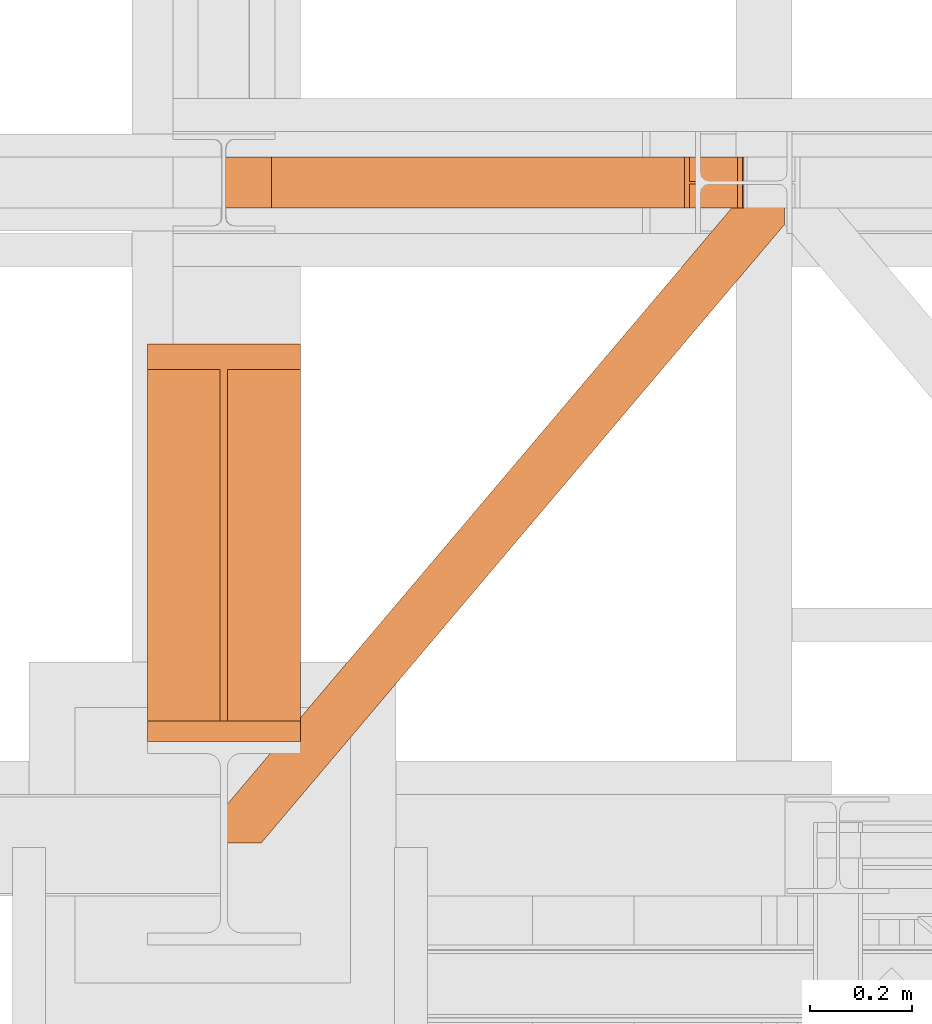
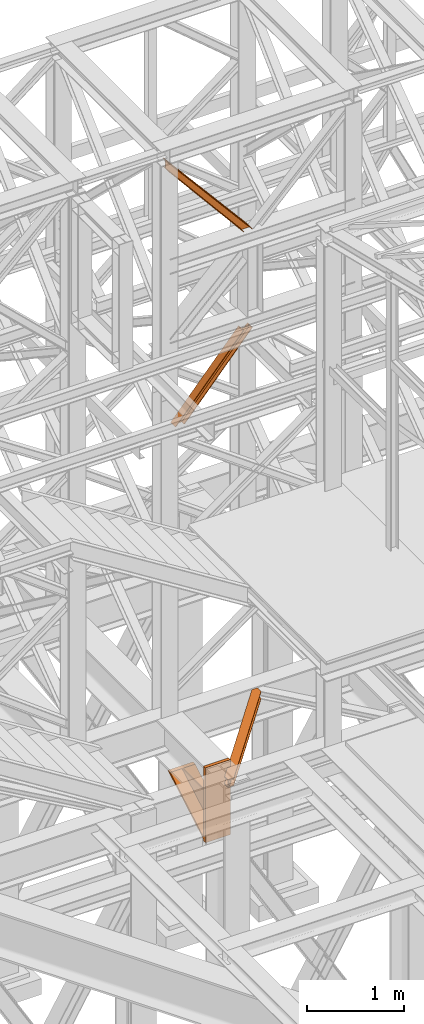
# One storey, part 106 of 208: 4 proxies.
"""IFC2X3 building model written with IfcOpenShell, lengths in millimetres."""

import ifcopenshell
import ifcopenshell.guid

model = None  # the IFC model being written
_history = None  # IfcOwnerHistory: only IFC2X3 demands one
_inside = {}  # id of a spatial element -> (the spatial element, [elements in it])
_under = {}  # id of a project, library or spatial element -> (it, [spatial elements below it])
_declared = {}  # id of a project -> (the project, [libraries it declares])
_typed = {}  # id of a type object -> (the type object, [elements of that type])
_made_of = {}  # id of a material, layer set ... -> (it, [elements and type objects made of it])


def new_model(schema):
    """Start an empty IFC model of exactly this schema.

    Asked for "IFC4X3", IfcOpenShell would pick the latest addendum, in which some entities
    have other attributes; the version numbers below select the first issue.
    IFC2X3 requires an IfcOwnerHistory on every rooted entity: one is made here for all.
    """
    global model, _history
    if schema == "IFC4X3":
        model = ifcopenshell.file(schema_version=(4, 3, 0, 0))
    else:
        model = ifcopenshell.file(schema=schema)
    _inside.clear()
    _under.clear()
    _declared.clear()
    _typed.clear()
    _made_of.clear()
    _history = None
    if model.schema == "IFC2X3":
        org = make("IfcOrganization", Name="unknown")
        user = make(
            "IfcPersonAndOrganization",
            ThePerson=make("IfcPerson", FamilyName="unknown"),
            TheOrganization=org,
        )
        app = make(
            "IfcApplication",
            ApplicationDeveloper=org,
            Version="unknown",
            ApplicationFullName="unknown",
            ApplicationIdentifier="unknown",
        )
        _history = make(
            "IfcOwnerHistory",
            OwningUser=user,
            OwningApplication=app,
            ChangeAction="ADDED",
            CreationDate=0,
        )
    return model


def make(cls, **values):
    """One entity of the class cls with the attributes given. An attribute that is None is left unset."""
    return model.create_entity(
        cls, **{name: value for name, value in values.items() if value is not None}
    )


def entity(cls, *values):
    """Any entity or typed value of the class cls, its attributes in the order of the schema. None: left unset."""
    e = model.create_entity(cls)
    for i, value in enumerate(values):
        if value is not None:
            e[i] = value
    return e


def rooted(cls, **values):
    """An entity with a GlobalId (a new one), such as an element, a storey or a relation."""
    return make(cls, GlobalId=ifcopenshell.guid.new(), OwnerHistory=_history, **values)


def si_unit(unit_type, name, prefix=None):
    """IfcSIUnit, for example si_unit("LENGTHUNIT", "METRE", prefix="MILLI")."""
    return make("IfcSIUnit", UnitType=unit_type, Prefix=prefix, Name=name)


def converted_unit(unit_type, name, factor, base, dimensions=None, offset=None):
    """IfcConversionBasedUnit, such as the inch: factor (a typed value) times the base unit."""
    return make(
        "IfcConversionBasedUnit"
        if offset is None
        else "IfcConversionBasedUnitWithOffset",
        ConversionOffset=offset,
        Dimensions=None
        if dimensions is None
        else entity("IfcDimensionalExponents", *dimensions),
        UnitType=unit_type,
        Name=name,
        ConversionFactor=make(
            "IfcMeasureWithUnit", ValueComponent=factor, UnitComponent=base
        ),
    )


def assignment(units):
    """IfcUnitAssignment: the units of a project."""
    return None if units is None else make("IfcUnitAssignment", Units=units)


def point(xyz):
    """IfcCartesianPoint."""
    return None if xyz is None else make("IfcCartesianPoint", Coordinates=xyz)


def direction(xyz):
    """IfcDirection."""
    return None if xyz is None else make("IfcDirection", DirectionRatios=xyz)


def frame(location, z_axis=None, x_axis=None):
    """IfcAxis2Placement3D, a coordinate frame: its origin and axes. An axis left out is left unset."""
    return make(
        "IfcAxis2Placement3D",
        Location=point(location),
        Axis=direction(z_axis),
        RefDirection=direction(x_axis),
    )


def origin():
    """The frame at (0, 0, 0) with its axes left unset."""
    return frame((0.0, 0.0, 0.0))


def origin_with_axes():
    """The frame at (0, 0, 0) with the z axis (0, 0, 1) and the x axis (1, 0, 0) written out."""
    return frame((0.0, 0.0, 0.0), z_axis=(0.0, 0.0, 1.0), x_axis=(1.0, 0.0, 0.0))


def place(relative_to, where):
    """IfcLocalPlacement: puts the frame where relative to a parent placement (None: the world)."""
    return make(
        "IfcLocalPlacement", PlacementRelTo=relative_to, RelativePlacement=where
    )


def context(
    kind, dimensions, precision=None, world=None, true_north=None, identifier=None
):
    """IfcGeometricRepresentationContext, for example the 3D "Model" context."""
    return make(
        "IfcGeometricRepresentationContext",
        ContextIdentifier=identifier,
        ContextType=kind,
        CoordinateSpaceDimension=dimensions,
        Precision=precision,
        WorldCoordinateSystem=world,
        TrueNorth=true_north,
    )


def subcontext(parent, identifier, kind, view, scale=None):
    """IfcGeometricRepresentationSubContext, for example "Body" below "Model"."""
    return make(
        "IfcGeometricRepresentationSubContext",
        ContextIdentifier=identifier,
        ContextType=kind,
        ParentContext=parent,
        TargetScale=scale,
        TargetView=view,
    )


def project(units=None, contexts=None):
    """IfcProject with its units and contexts."""
    return rooted(
        "IfcProject",
        Name="project",
        RepresentationContexts=contexts,
        UnitsInContext=assignment(units),
    )


def spatial(cls, under=None, at=None, **own):
    """A site, building, storey or space (cls), placed at a placement, below another one or the project."""
    s = rooted(cls, ObjectPlacement=at, **own)
    if under is not None:
        _under.setdefault(under.id(), (under, []))[1].append(s)
    return s


def faces_of(points, faces, orient=None, outer=None):
    """IfcFace entities. A face is a list of loops; a loop is a list of indices into points, from 0.

    orient and outer hold one flag for each loop. By default every Orientation is true, the
    first loop of a face is its IfcFaceOuterBound and the others are IfcFaceBound.
    """
    made = []
    for i, loops in enumerate(faces):
        bounds = []
        for j, loop in enumerate(loops):
            is_outer = j == 0 if outer is None else outer[i][j]
            bounds.append(
                make(
                    "IfcFaceOuterBound" if is_outer else "IfcFaceBound",
                    Bound=make("IfcPolyLoop", Polygon=[points[k] for k in loop]),
                    Orientation=True if orient is None else orient[i][j],
                )
            )
        made.append(make("IfcFace", Bounds=bounds))
    return made


def faceted_brep(points, faces, orient=None, outer=None, voids=None):
    """IfcFacetedBrep: a solid bounded by flat faces; with voids (closed shells), ...WithVoids."""
    shared = [point(p) for p in points]
    hull = make("IfcClosedShell", CfsFaces=faces_of(shared, faces, orient, outer))
    if voids is None:
        return make("IfcFacetedBrep", Outer=hull)
    return make(
        "IfcFacetedBrepWithVoids",
        Outer=hull,
        Voids=[
            make(cls, CfsFaces=faces_of(shared, fs, o, b)) for cls, fs, o, b in voids
        ],
    )


def shape(context_of_items, identifier, shape_type, items):
    """IfcShapeRepresentation: the items that make up one representation, for example the "Body"."""
    return make(
        "IfcShapeRepresentation",
        ContextOfItems=context_of_items,
        RepresentationIdentifier=identifier,
        RepresentationType=shape_type,
        Items=items,
    )


def made_of(thing, what):
    """Note that an element or type object is made of a material, layer set ...; save() writes the relation."""
    if what is not None:
        _made_of.setdefault(what.id(), (what, []))[1].append(thing)
    return thing


def element(
    cls,
    number,
    at=None,
    inside=None,
    cuts=None,
    type_object=None,
    material=None,
    context=None,
    identifier="Body",
    shape_type=None,
    held_by="IfcProductDefinitionShape",
    body=None,
    shapes=None,
    **own,
):
    """One element of the class cls, such as IfcWall. Its Tag is "e" and its number.

    at: its placement. inside: the storey or other place that contains it. cuts: it is an
    opening in that element (IfcRelVoidsElement). A single representation is given by context,
    identifier, shape_type and body (its items); several are given by shapes. held_by: the class
    of the entity that holds the representations. save() writes the other relations.
    """
    e = rooted(cls, Tag="e%d" % number, ObjectPlacement=at, **own)
    if body is not None:
        shapes = [shape(context, identifier, shape_type, body)]
    if shapes is not None:
        e.Representation = make(held_by, Representations=shapes)
    if inside is not None:
        _inside.setdefault(inside.id(), (inside, []))[1].append(e)
    if cuts is not None:
        rooted(
            "IfcRelVoidsElement", RelatingBuildingElement=cuts, RelatedOpeningElement=e
        )
    if type_object is not None:
        _typed.setdefault(type_object.id(), (type_object, []))[1].append(e)
    return made_of(e, material)


def aggregate(whole, parts):
    """IfcRelAggregates: a whole, such as a stair, and the parts it consists of."""
    return rooted("IfcRelAggregates", RelatingObject=whole, RelatedObjects=parts)


def save(model, path):
    """Write the relations noted so far, then the file.

    IfcRelAggregates (storeys below a building ...), IfcRelContainedInSpatialStructure (elements
    in a storey), IfcRelDefinesByType, IfcRelAssociatesMaterial and IfcRelDeclares: one each for
    every whole, place, type object, material and project.
    """
    for whole, parts in _under.values():
        aggregate(whole, parts)
    for where, things in _inside.values():
        rooted(
            "IfcRelContainedInSpatialStructure",
            RelatedElements=things,
            RelatingStructure=where,
        )
    for kind, things in _typed.values():
        rooted("IfcRelDefinesByType", RelatedObjects=things, RelatingType=kind)
    for what, things in _made_of.values():
        rooted("IfcRelAssociatesMaterial", RelatedObjects=things, RelatingMaterial=what)
    for by, libraries in _declared.values():
        rooted("IfcRelDeclares", RelatingContext=by, RelatedDefinitions=libraries)
    model.write(path)


model = new_model("IFC2X3")

# Units and contexts
model_context = context("Model", 3, precision=1e-05, world=origin())
plan_context = context("Plan", 3, precision=1e-05, world=origin())
body_context = subcontext(model_context, "Body", "Model", "MODEL_VIEW")
ifc_project = project(units=[si_unit("LENGTHUNIT", "METRE", prefix="MILLI"), converted_unit("PLANEANGLEUNIT", "DEGREE", entity("IfcPlaneAngleMeasure", 0.0174532925199433), si_unit("PLANEANGLEUNIT", "RADIAN"), dimensions=[0, 0, 0, 0, 0, 0, 0]), si_unit("AREAUNIT", "SQUARE_METRE"), si_unit("VOLUMEUNIT", "CUBIC_METRE")], contexts=[model_context, plan_context])

# Building, storey
building_placement = place(None, origin())
building = spatial("IfcBuilding", under=ifc_project, at=building_placement, CompositionType="COMPLEX")
storey_placement = place(building_placement, origin_with_axes())
storey = spatial("IfcBuildingStorey", under=building, at=storey_placement, Name="Geschoss", CompositionType="ELEMENT")

# Proxies
proxy_1_placement = place(storey_placement, frame((-0.7450314191753478, -17257.87439359531, 5101.990016164881), z_axis=(0.0, 0.0, 1.0), x_axis=(1.0, 0.0, 0.0)))
element("IfcBuildingElementProxy", 1, at=proxy_1_placement, inside=storey, context=body_context, shape_type="Brep", body=[
    faceted_brep([(1028.512359102908, 1290.610003345228, 8.010001311302403), (0.009999999999990905, 75.10721531451782, 8.010001311303313), (0.009999999999990905, 75.10721531451782, 0.01000000000021828), (1028.512359102908, 1290.610003345228, 0.01000000000021828), (1028.512359102908, 1290.610003345228, 0.01000000000021828), (0.009999999999990905, 75.10721531451782, 0.01000000000021828), (0.009999999999990905, 0.00999999999839929, 0.01000000000021828), (67.46148411605259, 0.00999999999839929, 0.01000000000021828), (1094.009999947844, 1213.20370052848, 0.01000000000021828), (1094.009999947844, 1290.610003345228, 0.01000000000021828), (1094.009999947844, 1213.20370052848, 0.01000000000021828), (67.46148411605259, 0.00999999999839929, 0.01000000000021828), (67.46148411605259, 0.00999999999839929, 8.010001311302403), (1094.009999947846, 1213.203700528482, 8.010001311302403), (1094.009999947846, 1213.203700528482, 8.010001311302403), (67.46148411605259, 0.00999999999839929, 8.010001311302403), (20.95815950654264, 0.00999999999839929, 8.010001311302403), (1094.009999947844, 1268.162175066993, 8.010001311302403), (1094.009999947844, 1268.162175066993, 8.010001311302403), (20.95815950654264, 0.00999999999839929, 8.010001311302403), (12.82264470841778, 0.00999999999839929, 9.253033826351384), (1094.009999947845, 1277.776874373869, 9.253033826351384), (1094.009999947845, 1277.776874373869, 9.253033826351384), (12.82264470841778, 0.00999999999839929, 9.253033826351384), (6.867038806687333, 0.00999999999839929, 13.79946006298087), (1094.009999947845, 1284.815317712277, 13.79946006298087), (1094.009999947845, 1284.815317712277, 13.79946006298087), (6.867038806687333, 0.00999999999839929, 13.79946006298087), (5.238725496361212, 0.00999999999839929, 20.01000141560962), (1094.009999947844, 1286.739687988118, 20.01000141561053), (1094.009999947844, 1286.739687988118, 20.01000141561053), (5.238725496361212, 0.00999999999839929, 20.01000141560962), (5.238725496361212, 0.00999999999839929, 76.01000128150008), (1094.009999947844, 1286.739687988116, 76.01000128150008), (1094.009999947844, 1286.739687988116, 76.01000128150008), (5.238725496361212, 0.00999999999839929, 76.01000128150008), (6.867038806687333, 0.00999999999839929, 82.2205407714846), (1094.009999947845, 1284.815317712277, 82.2205407714846), (1094.009999947845, 1284.815317712277, 82.2205407714846), (6.867038806687333, 0.00999999999839929, 82.2205407714846), (12.82264470841778, 0.00999999999839929, 86.76696700811317), (1094.009999947845, 1277.776874373869, 86.76696700811408), (1094.009999947845, 1277.776874373869, 86.76696700811408), (12.82264470841778, 0.00999999999839929, 86.76696700811317), (20.95815950654446, 0.00999999999839929, 88.00999952316306), (1094.009999947845, 1268.162175066993, 88.00999952316306), (1094.009999947845, 1268.162175066993, 88.00999952316306), (20.95815950654446, 0.00999999999839929, 88.00999952316306), (67.46148411605259, 0.00999999999839929, 88.00999952316397), (1094.009999947845, 1213.20370052848, 88.00999952316306), (1094.009999947845, 1213.20370052848, 88.00999952316306), (67.46148411605259, 0.00999999999839929, 88.00999952316397), (67.46148411605259, 0.00999999999839929, 96.01000083446525), (1094.009999947847, 1213.203700528484, 96.01000083446525), (1094.009999947847, 1213.203700528484, 96.01000083446525), (67.46148411605259, 0.00999999999839929, 96.01000083446525), (0.009999999999990905, 0.00999999999839929, 96.01000083446525), (0.009999999999990905, 75.10721531451782, 96.01000083446525), (1028.512359102909, 1290.610003345228, 96.01000083446525), (1094.009999947846, 1290.610003345228, 96.01000083446525), (1028.512359102909, 1290.610003345228, 96.01000083446525), (0.009999999999990905, 75.10721531451782, 96.01000083446525), (0.009999999999990905, 75.10721531451782, 88.00999952316306), (1028.512359102909, 1290.610003345228, 88.00999952316306), (1028.512359102909, 1290.610003345228, 88.00999952316306), (0.009999999999990905, 75.10721531451782, 88.00999952316306), (0.009999999999990905, 20.14874077600325, 88.00999952316215), (1075.015683712419, 1290.610003345228, 88.00999952316306), (1075.015683712419, 1290.610003345228, 88.00999952316306), (0.009999999999990905, 20.14874077600325, 88.00999952316215), (0.009999999999990905, 10.53404146912726, 86.76696700811499), (1083.151198510545, 1290.610003345228, 86.76696700811408), (1083.151198510545, 1290.610003345228, 86.76696700811408), (0.009999999999990905, 10.53404146912726, 86.76696700811499), (0.009999999999990905, 3.495598130721191, 82.2205407714855), (1089.106804412274, 1290.610003345228, 82.2205407714846), (1089.106804412274, 1290.610003345228, 82.2205407714846), (0.009999999999990905, 3.495598130721191, 82.2205407714855), (0.009999999999990905, 1.571227854878089, 76.01000128150008), (1090.735117722602, 1290.610003345228, 76.01000128150008), (1090.735117722602, 1290.610003345228, 76.01000128150008), (0.009999999999990905, 1.571227854878089, 76.01000128150008), (0.009999999999990905, 1.571227854878089, 20.01000141561053), (1090.735117722601, 1290.610003345228, 20.01000141561053), (1090.735117722601, 1290.610003345228, 20.01000141561053), (0.009999999999990905, 1.571227854878089, 20.01000141561053), (0.009999999999990905, 3.495598130721191, 13.79946006298087), (1089.106804412275, 1290.610003345228, 13.79946006298087), (1089.106804412275, 1290.610003345228, 13.79946006298087), (0.009999999999990905, 3.495598130721191, 13.79946006298087), (0.009999999999990905, 10.53404146912726, 9.253033826351384), (1083.151198510544, 1290.610003345228, 9.253033826351384), (1083.151198510544, 1290.610003345228, 9.253033826351384), (0.009999999999990905, 10.53404146912726, 9.253033826351384), (0.009999999999990905, 20.14874077600325, 8.010001311302403), (1075.015683712418, 1290.610003345228, 8.010001311302403), (1075.015683712418, 1290.610003345228, 8.010001311302403), (0.009999999999990905, 20.14874077600325, 8.010001311302403), (0.009999999999990905, 75.10721531451782, 8.010001311303313), (1028.512359102908, 1290.610003345228, 8.010001311302403), (1094.009999947844, 1213.20370052848, 0.01000000000021828), (1094.009999947846, 1213.203700528482, 8.010001311302403), (1094.009999947844, 1268.162175066993, 8.010001311302403), (1094.009999947845, 1277.776874373869, 9.253033826351384), (1094.009999947845, 1284.815317712277, 13.79946006298087), (1094.009999947844, 1286.739687988118, 20.01000141561053), (1094.009999947844, 1286.739687988116, 76.01000128150008), (1094.009999947845, 1284.815317712277, 82.2205407714846), (1094.009999947845, 1277.776874373869, 86.76696700811408), (1094.009999947845, 1268.162175066993, 88.00999952316306), (1094.009999947845, 1213.20370052848, 88.00999952316306), (1094.009999947847, 1213.203700528484, 96.01000083446525), (1094.009999947846, 1290.610003345228, 96.01000083446525), (1094.009999947844, 1290.610003345228, 0.01000000000021828), (1094.009999947846, 1290.610003345228, 96.01000083446525), (1028.512359102909, 1290.610003345228, 96.01000083446525), (1028.512359102909, 1290.610003345228, 88.00999952316306), (1075.015683712419, 1290.610003345228, 88.00999952316306), (1083.151198510545, 1290.610003345228, 86.76696700811408), (1089.106804412274, 1290.610003345228, 82.2205407714846), (1090.735117722602, 1290.610003345228, 76.01000128150008), (1090.735117722601, 1290.610003345228, 20.01000141561053), (1089.106804412275, 1290.610003345228, 13.79946006298087), (1083.151198510544, 1290.610003345228, 9.253033826351384), (1075.015683712418, 1290.610003345228, 8.010001311302403), (1028.512359102908, 1290.610003345228, 8.010001311302403), (1028.512359102908, 1290.610003345228, 0.01000000000021828), (1094.009999947844, 1290.610003345228, 0.01000000000021828), (0.009999999999990905, 75.10721531451782, 0.01000000000021828), (0.009999999999990905, 75.10721531451782, 8.010001311303313), (0.009999999999990905, 20.14874077600325, 8.010001311302403), (0.009999999999990905, 10.53404146912726, 9.253033826351384), (0.009999999999990905, 3.495598130721191, 13.79946006298087), (0.009999999999990905, 1.571227854878089, 20.01000141561053), (0.009999999999990905, 1.571227854878089, 76.01000128150008), (0.009999999999990905, 3.495598130721191, 82.2205407714855), (0.009999999999990905, 10.53404146912726, 86.76696700811499), (0.009999999999990905, 20.14874077600325, 88.00999952316215), (0.009999999999990905, 75.10721531451782, 88.00999952316306), (0.009999999999990905, 75.10721531451782, 96.01000083446525), (0.009999999999990905, 0.00999999999839929, 96.01000083446525), (0.009999999999990905, 0.00999999999839929, 0.01000000000021828), (67.46148411605259, 0.00999999999839929, 0.01000000000021828), (0.009999999999990905, 0.00999999999839929, 0.01000000000021828), (0.009999999999990905, 0.00999999999839929, 96.01000083446525), (67.46148411605259, 0.00999999999839929, 96.01000083446525), (67.46148411605259, 0.00999999999839929, 88.00999952316397), (20.95815950654446, 0.00999999999839929, 88.00999952316306), (12.82264470841778, 0.00999999999839929, 86.76696700811317), (6.867038806687333, 0.00999999999839929, 82.2205407714846), (5.238725496361212, 0.00999999999839929, 76.01000128150008), (5.238725496361212, 0.00999999999839929, 20.01000141560962), (6.867038806687333, 0.00999999999839929, 13.79946006298087), (12.82264470841778, 0.00999999999839929, 9.253033826351384), (20.95815950654264, 0.00999999999839929, 8.010001311302403), (67.46148411605259, 0.00999999999839929, 8.010001311302403)], [[[0, 1, 2, 3]], [[4, 5, 6, 7, 8, 9]], [[10, 11, 12, 13]], [[14, 15, 16, 17]], [[18, 19, 20, 21]], [[22, 23, 24, 25]], [[26, 27, 28, 29]], [[30, 31, 32, 33]], [[34, 35, 36, 37]], [[38, 39, 40, 41]], [[42, 43, 44, 45]], [[46, 47, 48, 49]], [[50, 51, 52, 53]], [[54, 55, 56, 57, 58, 59]], [[60, 61, 62, 63]], [[64, 65, 66, 67]], [[68, 69, 70, 71]], [[72, 73, 74, 75]], [[76, 77, 78, 79]], [[80, 81, 82, 83]], [[84, 85, 86, 87]], [[88, 89, 90, 91]], [[92, 93, 94, 95]], [[96, 97, 98, 99]], [[100, 101, 102, 103, 104, 105, 106, 107, 108, 109, 110, 111, 112, 113]], [[114, 115, 116, 117, 118, 119, 120, 121, 122, 123, 124, 125, 126, 127]], [[128, 129, 130, 131, 132, 133, 134, 135, 136, 137, 138, 139, 140, 141]], [[142, 143, 144, 145, 146, 147, 148, 149, 150, 151, 152, 153, 154, 155]]], orient=[[False], [False], [False], [False], [False], [False], [False], [False], [False], [False], [False], [False], [False], [False], [False], [False], [False], [False], [False], [False], [False], [False], [False], [False], [False], [False], [False], [False]]),
])
proxy_2_placement = place(storey_placement, frame((86.8694860052658, -16012.57439031789, 8868.608403143522), z_axis=(0.0, 0.0, 1.0), x_axis=(1.0, 0.0, 0.0)))
element("IfcBuildingElementProxy", 2, at=proxy_2_placement, inside=storey, context=body_context, shape_type="Brep", body=[
    faceted_brep([(923.4334083348583, 0.01000000000021828, 935.3916305163348), (113.0905292499062, 0.01000000000021828, 0.01000000000021828), (103.6671518124128, 0.01000000000021828, 0.01000000000021828), (914.0100308973676, 0.01000000000021828, 935.3916305163366), (923.4334083348583, 100.0100000000002, 935.3916305163348), (113.0905292499062, 100.0100000000002, 0.01000000000021828), (113.0905292499062, 0.01000000000021828, 0.01000000000021828), (923.4334083348583, 0.01000000000021828, 935.3916305163348), (914.0100308973676, 100.0100000000002, 935.3916305163366), (103.6671518124128, 100.0100000000002, 0.01000000000021828), (113.0905292499062, 100.0100000000002, 0.01000000000021828), (923.4334083348583, 100.0100000000002, 935.3916305163348), (914.0100308973676, 52.51000000000022, 935.3916305163366), (103.6671518124128, 52.51000000000022, 0.01000000000021828), (103.6671518124128, 100.0100000000002, 0.01000000000021828), (914.0100308973676, 100.0100000000002, 935.3916305163366), (819.7762565224418, 52.51000000000022, 935.3916305163348), (9.433377437491572, 52.51000000000022, 0.01000000000021828), (103.6671518124128, 52.51000000000022, 0.01000000000021828), (914.0100308973676, 52.51000000000022, 935.3916305163366), (819.7762565224455, 100.0100000000002, 935.3916305163348), (9.43337743749521, 100.0100000000002, 0.01000000000021828), (9.433377437491572, 52.51000000000022, 0.01000000000021828), (819.7762565224418, 52.51000000000022, 935.3916305163348), (810.352879084953, 100.0100000000002, 935.3916305163348), (0.009999999999990905, 100.0100000000002, 0.01000000000021828), (9.43337743749521, 100.0100000000002, 0.01000000000021828), (819.7762565224455, 100.0100000000002, 935.3916305163348), (810.3528790849493, 0.01000000000021828, 935.3916305163348), (0.009999999999990905, 0.01000000000021828, 0.01000000000021828), (0.009999999999990905, 100.0100000000002, 0.01000000000021828), (810.352879084953, 100.0100000000002, 935.3916305163348), (819.7762565224455, 0.01000000000021828, 935.3916305163348), (9.433377437493391, 0.01000000000021828, 0.01000000000021828), (0.009999999999990905, 0.01000000000021828, 0.01000000000021828), (810.3528790849493, 0.01000000000021828, 935.3916305163348), (819.7762565224473, 47.51000000000022, 935.391630516333), (9.433377437493391, 47.51000000000022, 0.01000000000021828), (9.433377437493391, 0.01000000000021828, 0.01000000000021828), (819.7762565224455, 0.01000000000021828, 935.3916305163348), (914.0100308973676, 47.51000000000022, 935.3916305163366), (103.6671518124128, 47.51000000000022, 0.01000000000021828), (9.433377437493391, 47.51000000000022, 0.01000000000021828), (819.7762565224473, 47.51000000000022, 935.391630516333), (914.0100308973676, 0.01000000000021828, 935.3916305163366), (103.6671518124128, 0.01000000000021828, 0.01000000000021828), (103.6671518124128, 47.51000000000022, 0.01000000000021828), (914.0100308973676, 47.51000000000022, 935.3916305163366), (914.0100308973676, 0.01000000000021828, 935.3916305163366), (914.0100308973676, 47.51000000000022, 935.3916305163366), (819.7762565224473, 47.51000000000022, 935.391630516333), (819.7762565224455, 0.01000000000021828, 935.3916305163348), (810.3528790849493, 0.01000000000021828, 935.3916305163348), (810.352879084953, 100.0100000000002, 935.3916305163348), (819.7762565224455, 100.0100000000002, 935.3916305163348), (819.7762565224418, 52.51000000000022, 935.3916305163348), (914.0100308973676, 52.51000000000022, 935.3916305163366), (914.0100308973676, 100.0100000000002, 935.3916305163366), (923.4334083348583, 100.0100000000002, 935.3916305163348), (923.4334083348583, 0.01000000000021828, 935.3916305163348), (113.0905292499062, 0.01000000000021828, 0.01000000000021828), (113.0905292499062, 100.0100000000002, 0.01000000000021828), (103.6671518124128, 100.0100000000002, 0.01000000000021828), (103.6671518124128, 52.51000000000022, 0.01000000000021828), (9.433377437491572, 52.51000000000022, 0.01000000000021828), (9.43337743749521, 100.0100000000002, 0.01000000000021828), (0.009999999999990905, 100.0100000000002, 0.01000000000021828), (0.009999999999990905, 0.01000000000021828, 0.01000000000021828), (9.433377437493391, 0.01000000000021828, 0.01000000000021828), (9.433377437493391, 47.51000000000022, 0.01000000000021828), (103.6671518124128, 47.51000000000022, 0.01000000000021828), (103.6671518124128, 0.01000000000021828, 0.01000000000021828)], [[[0, 1, 2, 3]], [[4, 5, 6, 7]], [[8, 9, 10, 11]], [[12, 13, 14, 15]], [[16, 17, 18, 19]], [[20, 21, 22, 23]], [[24, 25, 26, 27]], [[28, 29, 30, 31]], [[32, 33, 34, 35]], [[36, 37, 38, 39]], [[40, 41, 42, 43]], [[44, 45, 46, 47]], [[48, 49, 50, 51, 52, 53, 54, 55, 56, 57, 58, 59]], [[60, 61, 62, 63, 64, 65, 66, 67, 68, 69, 70, 71]]], orient=[[False], [False], [False], [False], [False], [False], [False], [False], [False], [False], [False], [False], [False], [False]]),
])
proxy_3_placement = place(storey_placement, frame((-3.495031404277825, -16012.57439031789, 11048.99005869381), z_axis=(0.0, 0.0, 1.0), x_axis=(1.0, 0.0, 0.0)))
element("IfcBuildingElementProxy", 3, at=proxy_3_placement, inside=storey, context=body_context, shape_type="Brep", body=[
    faceted_brep([(1016.75998845905, 0.01000000000021828, 0.01000000000203727), (1007.336611021559, 0.01000000000021828, 0.01000000000021828), (0.009999999999990905, 0.01000000000021828, 1191.327434941315), (0.009999999999990905, 0.01000000000021828, 1201.010000000002), (1016.75998845905, 100.0100000000002, 0.01000000000203727), (1016.75998845905, 0.01000000000021828, 0.01000000000203727), (0.009999999999990905, 0.01000000000021828, 1201.010000000002), (0.009999999999990905, 100.0100000000002, 1201.010000000004), (1007.336611021559, 100.0100000000002, 0.01000000000021828), (1016.75998845905, 100.0100000000002, 0.01000000000203727), (0.009999999999990905, 100.0100000000002, 1201.010000000004), (0.009999999999990905, 100.0100000000002, 1191.327434941315), (1007.336611021559, 52.51000000000022, 0.01000000000021828), (1007.336611021559, 100.0100000000002, 0.01000000000021828), (0.009999999999990905, 100.0100000000002, 1191.327434941315), (0.009999999999990905, 52.51000000000022, 1191.327434941315), (913.1028366466332, 52.51000000000022, 0.01000000000203727), (1007.336611021559, 52.51000000000022, 0.01000000000021828), (0.009999999999990905, 52.51000000000022, 1191.327434941315), (0.009999999999990905, 52.51000000000022, 1094.501784354448), (913.1028366466369, 100.0100000000002, 0.01000000000203727), (913.1028366466332, 52.51000000000022, 0.01000000000203727), (0.009999999999990905, 52.51000000000022, 1094.501784354448), (0.009999999999990905, 100.0100000000002, 1094.501784354448), (903.6794592091444, 100.0100000000002, 0.01000000000203727), (913.1028366466369, 100.0100000000002, 0.01000000000203727), (0.009999999999990905, 100.0100000000002, 1094.501784354448), (0.009999999999990905, 100.0100000000002, 1084.819219295761), (903.6794592091408, 0.01000000000021828, 0.01000000000203727), (903.6794592091444, 100.0100000000002, 0.01000000000203727), (0.009999999999990905, 100.0100000000002, 1084.819219295761), (0.009999999999990905, 0.01000000000021828, 1084.819219295761), (913.1028366466369, 0.01000000000021828, 0.01000000000203727), (903.6794592091408, 0.01000000000021828, 0.01000000000203727), (0.009999999999990905, 0.01000000000021828, 1084.819219295761), (0.009999999999990905, 0.01000000000021828, 1094.501784354448), (913.1028366466387, 47.51000000000022, 0.01000000000385626), (913.1028366466369, 0.01000000000021828, 0.01000000000203727), (0.009999999999990905, 0.01000000000021828, 1094.501784354448), (0.009999999999990905, 47.51000000000022, 1094.501784354448), (1007.336611021559, 47.51000000000022, 0.01000000000021828), (913.1028366466387, 47.51000000000022, 0.01000000000385626), (0.009999999999990905, 47.51000000000022, 1094.501784354448), (0.009999999999990905, 47.51000000000022, 1191.327434941315), (1007.336611021559, 0.01000000000021828, 0.01000000000021828), (1007.336611021559, 47.51000000000022, 0.01000000000021828), (0.009999999999990905, 47.51000000000022, 1191.327434941315), (0.009999999999990905, 0.01000000000021828, 1191.327434941315), (0.009999999999990905, 0.01000000000021828, 1201.010000000002), (0.009999999999990905, 0.01000000000021828, 1191.327434941315), (0.009999999999990905, 47.51000000000022, 1191.327434941315), (0.009999999999990905, 47.51000000000022, 1094.501784354448), (0.009999999999990905, 0.01000000000021828, 1094.501784354448), (0.009999999999990905, 0.01000000000021828, 1084.819219295761), (0.009999999999990905, 100.0100000000002, 1084.819219295761), (0.009999999999990905, 100.0100000000002, 1094.501784354448), (0.009999999999990905, 52.51000000000022, 1094.501784354448), (0.009999999999990905, 52.51000000000022, 1191.327434941315), (0.009999999999990905, 100.0100000000002, 1191.327434941315), (0.009999999999990905, 100.0100000000002, 1201.010000000004), (1007.336611021559, 0.01000000000021828, 0.01000000000021828), (1016.75998845905, 0.01000000000021828, 0.01000000000203727), (1016.75998845905, 100.0100000000002, 0.01000000000203727), (1007.336611021559, 100.0100000000002, 0.01000000000021828), (1007.336611021559, 52.51000000000022, 0.01000000000021828), (913.1028366466332, 52.51000000000022, 0.01000000000203727), (913.1028366466369, 100.0100000000002, 0.01000000000203727), (903.6794592091444, 100.0100000000002, 0.01000000000203727), (903.6794592091408, 0.01000000000021828, 0.01000000000203727), (913.1028366466369, 0.01000000000021828, 0.01000000000203727), (913.1028366466387, 47.51000000000022, 0.01000000000385626), (1007.336611021559, 47.51000000000022, 0.01000000000021828)], [[[0, 1, 2, 3]], [[4, 5, 6, 7]], [[8, 9, 10, 11]], [[12, 13, 14, 15]], [[16, 17, 18, 19]], [[20, 21, 22, 23]], [[24, 25, 26, 27]], [[28, 29, 30, 31]], [[32, 33, 34, 35]], [[36, 37, 38, 39]], [[40, 41, 42, 43]], [[44, 45, 46, 47]], [[48, 49, 50, 51, 52, 53, 54, 55, 56, 57, 58, 59]], [[60, 61, 62, 63, 64, 65, 66, 67, 68, 69, 70, 71]]], orient=[[False], [False], [False], [False], [False], [False], [False], [False], [False], [False], [False], [False], [False], [False]]),
])
proxy_4_placement = place(storey_placement, frame((-156.7450314713297, -17058.57439531565, 4339.230005364416), z_axis=(0.0, 0.0, 1.0), x_axis=(1.0, 0.0, 0.0)))
element("IfcBuildingElementProxy", 4, at=proxy_4_placement, inside=storey, context=body_context, shape_type="Brep", body=[
    faceted_brep([(0.01000000000021828, 40.0099999999984, 18.61000000000058), (300.0100000000002, 40.0099999999984, 18.61000000000058), (300.01, 779.8719999999994, 445.7700000000004), (0.009999999999990905, 779.8719999999994, 445.7700000000004), (0.009999999999990905, 779.8719999999994, 445.7700000000004), (300.01, 779.8719999999994, 445.7700000000004), (300.01, 729.8160000000007, 445.7710000000006), (157.51, 729.8160000000007, 445.7710000000006), (142.51, 729.8160000000007, 445.7710000000006), (0.009999999999990905, 729.8160000000007, 445.7710000000006), (0.009999999999990905, 729.8160000000007, 445.7710000000006), (142.51, 729.8160000000007, 445.7710000000006), (142.5100000000002, 40.0099999999984, 47.51000000000022), (0.01000000000021828, 40.0099999999984, 47.51000000000022), (157.5100000000002, 40.0099999999984, 47.51000000000022), (157.51, 729.8160000000007, 445.7710000000006), (300.01, 729.8160000000007, 445.7710000000006), (300.0100000000002, 40.0099999999984, 47.51000000000022), (0.01000000000021828, 40.0099999999984, 18.61000000000058), (0.009999999999990905, 779.8719999999994, 445.7700000000004), (0.009999999999990905, 729.8160000000007, 445.7710000000006), (0.01000000000021828, 40.0099999999984, 47.51000000000022), (0.01000000000016144, 40.0099999999984, 945.7700000000004), (0.01000000000016144, 0.00999999999839929, 945.7700000000004), (0.01000000000021828, 0.00999999999839929, 0.01000000000021828), (0.01000000000021828, 40.0099999999984, 0.01000000000021828), (300.0100000000001, 0.01000000000203727, 945.7700000000004), (300.0100000000001, 40.0099999999984, 945.7700000000004), (300.0100000000002, 40.0099999999984, 47.51000000000022), (300.01, 729.8160000000007, 445.7710000000006), (300.01, 779.8719999999994, 445.7700000000004), (300.0100000000002, 40.0099999999984, 18.61000000000058), (300.0100000000002, 40.0099999999984, 0.01000000000021828), (300.0100000000002, 0.00999999999839929, 0.01000000000021828), (300.0100000000001, 0.01000000000203727, 945.7700000000004), (0.01000000000016144, 0.00999999999839929, 945.7700000000004), (0.01000000000016144, 40.0099999999984, 945.7700000000004), (300.0100000000001, 40.0099999999984, 945.7700000000004), (300.0100000000001, 40.0099999999984, 945.7700000000004), (0.01000000000016144, 40.0099999999984, 945.7700000000004), (0.01000000000021828, 40.0099999999984, 47.51000000000022), (142.5100000000002, 40.0099999999984, 47.51000000000022), (142.5100000000002, 40.0099999999984, 445.7700000000004), (157.5100000000002, 40.0099999999984, 445.7700000000004), (157.5100000000002, 40.0099999999984, 47.51000000000022), (300.0100000000002, 40.0099999999984, 47.51000000000022), (300.0100000000002, 40.0099999999984, 18.61000000000058), (0.01000000000021828, 40.0099999999984, 18.61000000000058), (0.01000000000021828, 40.0099999999984, 0.01000000000021828), (300.0100000000002, 40.0099999999984, 0.01000000000021828), (300.0100000000002, 40.0099999999984, 0.01000000000021828), (0.01000000000021828, 40.0099999999984, 0.01000000000021828), (0.01000000000021828, 0.00999999999839929, 0.01000000000021828), (300.0100000000002, 0.00999999999839929, 0.01000000000021828), (300.0100000000002, 0.00999999999839929, 0.01000000000021828), (0.01000000000021828, 0.00999999999839929, 0.01000000000021828), (0.01000000000016144, 0.00999999999839929, 945.7700000000004), (300.0100000000001, 0.01000000000203727, 945.7700000000004), (142.51, 729.8160000000007, 445.7710000000006), (157.51, 729.8160000000007, 445.7710000000006), (157.5100000000002, 40.0099999999984, 445.7700000000004), (142.5100000000002, 40.0099999999984, 445.7700000000004), (142.5100000000002, 40.0099999999984, 47.51000000000022), (142.51, 729.8160000000007, 445.7710000000006), (142.5100000000002, 40.0099999999984, 445.7700000000004), (157.5100000000002, 40.0099999999984, 47.51000000000022), (157.5100000000002, 40.0099999999984, 445.7700000000004), (157.51, 729.8160000000007, 445.7710000000006)], [[[0, 1, 2, 3]], [[4, 5, 6, 7, 8, 9]], [[10, 11, 12, 13]], [[14, 15, 16, 17]], [[18, 19, 20, 21, 22, 23, 24, 25]], [[26, 27, 28, 29, 30, 31, 32, 33]], [[34, 35, 36, 37]], [[38, 39, 40, 41, 42, 43, 44, 45]], [[46, 47, 48, 49]], [[50, 51, 52, 53]], [[54, 55, 56, 57]], [[58, 59, 60, 61]], [[62, 63, 64]], [[65, 66, 67]]], orient=[[False], [False], [False], [False], [False], [False], [False], [False], [False], [False], [False], [False], [False], [False]]),
])

save(model, "model.ifc")
